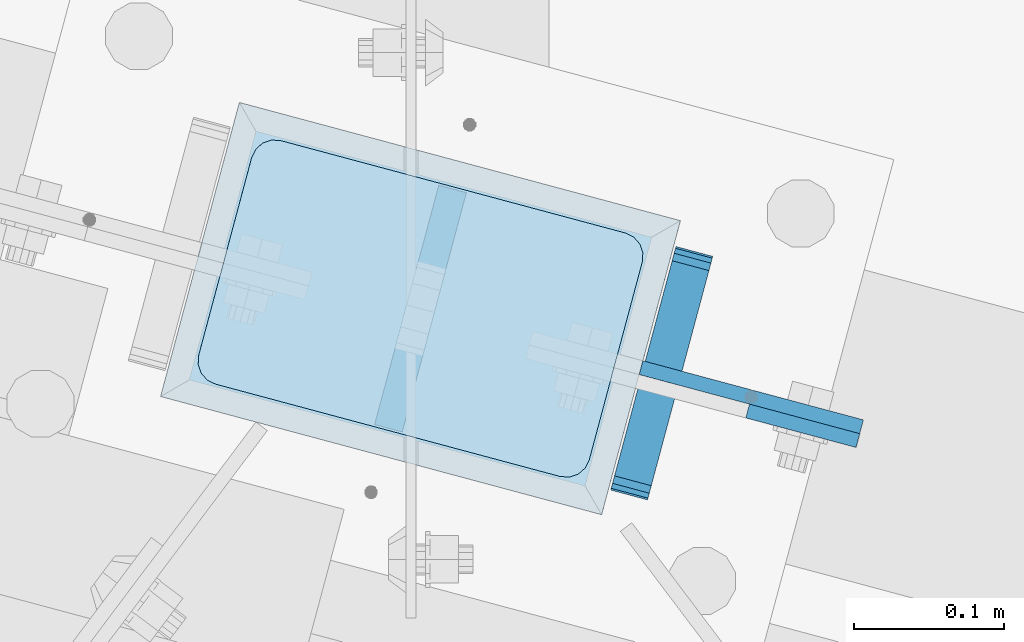
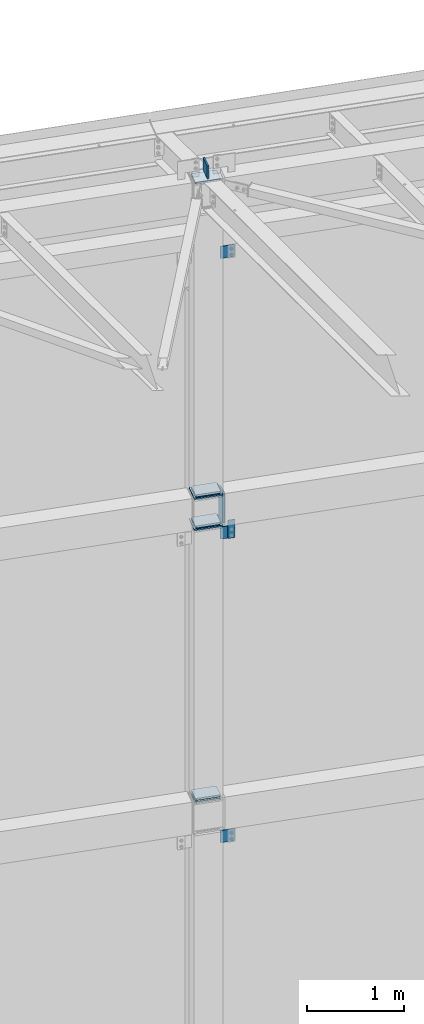
# One storey, part 1689 of 1763: 15 plates, 2 elements without a shape of their own.
"""IFC2X3 building model written with IfcOpenShell, lengths in millimetres."""

from ifc_helpers import new_model, si_unit, frame, origin_with_axes, place, context, subcontext, project, spatial, faceted_brep, material, type_object, element, aggregate, save


model = new_model("IFC2X3")

# Units and contexts
model_context = context("Model", 3, precision=1e-05, world=origin_with_axes())
body_context = subcontext(model_context, "Body", "Model", "MODEL_VIEW")
ifc_project = project(units=[si_unit("LENGTHUNIT", "METRE", prefix="MILLI"), si_unit("AREAUNIT", "SQUARE_METRE"), si_unit("VOLUMEUNIT", "CUBIC_METRE"), si_unit("MASSUNIT", "GRAM", prefix="KILO"), si_unit("TIMEUNIT", "SECOND"), si_unit("PLANEANGLEUNIT", "RADIAN"), si_unit("SOLIDANGLEUNIT", "STERADIAN"), si_unit("THERMODYNAMICTEMPERATUREUNIT", "DEGREE_CELSIUS"), si_unit("LUMINOUSINTENSITYUNIT", "LUMEN")], contexts=[model_context])

# Site, building, storey
site_placement = place(None, origin_with_axes())
site = spatial("IfcSite", under=ifc_project, at=site_placement, CompositionType="ELEMENT")
building_placement = place(site_placement, origin_with_axes())
building = spatial("IfcBuilding", under=site, at=building_placement, Name="Undefined", CompositionType="ELEMENT")
storey_placement = place(building_placement, origin_with_axes())
storey = spatial("IfcBuildingStorey", under=building, at=storey_placement, Name="Undefined", CompositionType="ELEMENT", Elevation=0.0)

# Assembly, plates
assembly_1_placement = place(storey_placement, origin_with_axes())
assembly_1 = element("IfcElementAssembly", 1, at=assembly_1_placement, inside=storey, Name="BEAM", AssemblyPlace="NOTDEFINED", PredefinedType="RIGID_FRAME")
ifc_material_1 = material(Name="STEEL/A36")
plate_type_1 = type_object("IfcPlateType", PredefinedType="NOTDEFINED")
plate_1_placement = place(assembly_1_placement, frame((-30890.9582946907, 64318.5909146449, 8077.19999084485), z_axis=(0.0, 0.0, -1.0), x_axis=(0.965925826295336, -0.25881904507913, 0.0)))
plate_1 = element("IfcPlate", 2, at=plate_1_placement, type_object=plate_type_1, material=ifc_material_1, Name="PLATE", context=body_context, shape_type="Brep", body=[
    faceted_brep([(0.0, -4.76249999999982, 0.0), (-2.83762346953154e-10, -4.7624999996915, 228.600006103516), (-2.83762346953154e-10, 4.76250000028813, 228.600006103517), (0.0, 4.76249999999982, 0.0), (76.1999969480166, -4.76249999961874, 228.600006103516), (76.1999969480166, 4.76250000036089, 228.600006103517), (76.1999969482931, -4.76249999991705, 0.0), (76.1999969482931, 4.76250000006257, 1.81898940354586e-12)], [[[0, 1, 2, 3]], [[1, 4, 5, 2]], [[4, 6, 7, 5]], [[6, 0, 3, 7]], [[5, 7, 3, 2]], [[6, 4, 1, 0]]]),
])
plate_type_2 = type_object("IfcPlateType", PredefinedType="NOTDEFINED")
plate_2_placement = place(assembly_1_placement, frame((-30926.5066305647, 64425.0894095407, 8094.69625868207), z_axis=(-1.25579324012506e-05, -4.68677477038e-05, 0.999999998822856), x_axis=(-0.258819045024454, -0.965925825091317, -4.85210000061005e-05)))
plate_2 = element("IfcPlate", 3, at=plate_2_placement, type_object=plate_type_2, material=ifc_material_1, Name="PLATE", context=body_context, shape_type="Brep", body=[
    faceted_brep([(-0.000210669619264081, -12.6999999999534, 15.8747893276304), (-0.0047190601399052, -12.6999999998734, 355.599795431186), (-0.00471906022721669, 12.7000000000335, 355.599795431181), (-0.000210669699299615, 12.6999999999462, 15.874789327625), (1.2036328949398, -12.6999999998734, 361.674959615151), (1.20363289484521, 12.7000000000189, 361.674959615146), (4.64488630341657, -12.6999999998734, 366.825251770753), (4.64488630330743, 12.7000000000189, 366.825251770748), (9.79513279069943, -12.6999999998807, 370.266573526937), (9.79513279059029, 12.7000000000116, 370.266573526933), (15.870280938434, -12.6999999998952, 371.47500610361), (15.8702809383467, 12.7000000000044, 371.475006103608), (152.395291187866, -12.7000000001281, 371.475006103574), (152.395291187757, 12.6999999997643, 371.475006103572), (158.470342028959, -12.7000000001353, 370.266613832635), (158.47034202885, 12.699999999757, 370.266613832629), (163.620536872309, -12.7000000001644, 366.825400721296), (163.620536872222, 12.6999999997352, 366.825400721291), (167.061818314192, -12.7000000001644, 361.675251535087), (167.06181831409, 12.6999999997279, 361.675251535082), (168.270291186484, -12.7000000001644, 355.600216727018), (168.270291186389, 12.6999999997279, 355.600216727014), (168.274798528968, -12.7000000002445, 15.8752106238717), (168.274798528873, 12.6999999996478, 15.8752106238662), (167.066446559853, -12.7000000002445, 9.80004645495683), (167.066446559766, 12.6999999996551, 9.80004645495319), (163.625193148131, -12.7000000002372, 4.64975431598214), (163.625193148022, 12.6999999996478, 4.64975431597668), (158.474946666858, -12.7000000002372, 1.2084325724245), (158.474946666771, 12.6999999996624, 1.20843257241904), (152.399798530452, -12.7000000002226, 4.20186552219093e-10), (152.399798530358, 12.6999999996697, 4.14729584008455e-10), (15.8747893290638, -12.6999999999898, 4.72937244921923e-11), (15.8747893289692, 12.6999999999098, 4.36557456851006e-11), (9.79973849928501, -12.699999999968, 1.20839226628777), (9.79973849918315, 12.6999999999243, 1.20839226628414), (4.64954366190068, -12.699999999968, 4.6496053649953), (4.64954366179882, 12.6999999999316, 4.64960536499166), (1.20826221675816, -12.6999999999607, 9.79975453459156), (1.20826221665629, 12.6999999999462, 9.79975453458792)], [[[0, 1, 2, 3]], [[1, 4, 5, 2]], [[4, 6, 7, 5]], [[6, 8, 9, 7]], [[8, 10, 11, 9]], [[10, 12, 13, 11]], [[12, 14, 15, 13]], [[14, 16, 17, 15]], [[16, 18, 19, 17]], [[18, 20, 21, 19]], [[20, 22, 23, 21]], [[22, 24, 25, 23]], [[24, 26, 27, 25]], [[26, 28, 29, 27]], [[28, 30, 31, 29]], [[30, 32, 33, 31]], [[32, 34, 35, 33]], [[34, 36, 37, 35]], [[36, 38, 39, 37]], [[38, 0, 3, 39]], [[5, 7, 9, 11, 13, 15, 17, 19, 21, 23, 25, 27, 29, 31, 33, 35, 37, 39, 3, 2]], [[38, 36, 34, 32, 30, 28, 26, 24, 22, 20, 18, 16, 14, 12, 10, 8, 6, 4, 1, 0]]]),
])
aggregate(assembly_1, [plate_2, plate_1])

assembly_2_placement = place(storey_placement, origin_with_axes())
assembly_2 = element("IfcElementAssembly", 4, at=assembly_2_placement, inside=storey, Name="COLUMN", AssemblyPlace="NOTDEFINED", PredefinedType="RIGID_FRAME")
plate_3_placement = place(assembly_2_placement, frame((-31217.8672023227, 64503.1592394629, 12417.425), z_axis=(0.965913267114843, -0.258865912030785, 0.0), x_axis=(-0.258865912030778, -0.965913267114844, 3.00823476209188e-08)))
plate_3 = element("IfcPlate", 5, at=plate_3_placement, type_object=plate_type_2, material=ifc_material_1, Name="PLATE", context=body_context, shape_type="Brep", body=[
    faceted_brep([(-2.18278728425503e-11, -12.7000000000007, 15.875), (-1.67347025126219e-10, -12.7000000000007, 253.999999999985), (-1.67347025126219e-10, 12.7000000000007, 253.999999999985), (-2.18278728425503e-11, 12.7000000000007, 15.875), (1.20841242121242, -12.7000000000007, 260.075099488779), (1.20841242121242, 12.7000000000007, 260.075099488779), (4.649679848495, -12.7000000000007, 265.225320151323), (4.649679848495, 12.7000000000007, 265.225320151323), (9.79990051103232, -12.7000000000007, 268.666587578606), (9.79990051103232, 12.7000000000007, 268.666587578606), (15.8749999998181, -12.7000000000007, 269.874999999993), (15.8749999998181, 12.7000000000007, 269.874999999993), (152.400009155084, -12.7000000000007, 269.875000000073), (152.400009155084, 12.7000000000007, 269.875000000073), (158.475108643877, -12.7000000000007, 268.6665875787), (158.475108643877, 12.7000000000007, 268.6665875787), (163.625329306422, -12.7000000000007, 265.225320151425), (163.625329306422, 12.7000000000007, 265.225320151425), (167.066596733705, -12.7000000000007, 260.07509948888), (167.066596733705, 12.7000000000007, 260.07509948888), (168.275009155092, -12.7000000000007, 254.000000000087), (168.275009155092, 12.7000000000007, 254.000000000087), (168.275009155237, -12.7000000000007, 15.8750000001019), (168.275009155237, 12.7000000000007, 15.8750000001019), (167.066596733865, -12.7000000000007, 9.79990051130881), (167.066596733865, 12.7000000000007, 9.79990051130881), (163.625329306582, -12.7000000000007, 4.64967984876421), (163.625329306582, 12.7000000000007, 4.64967984876421), (158.475108644045, -12.7000000000007, 1.20841242148163), (158.475108644045, 12.7000000000007, 1.20841242148163), (152.400000000001, -12.6999998092651, 0.0), (152.400000000001, 12.6999998092651, 0.0), (15.8749999999854, -12.7000000000007, 0.0), (15.8749999999854, 12.7000000000007, 0.0), (9.79990051119239, -12.7000000000007, 1.20841242137976), (9.79990051119239, 12.7000000000007, 1.20841242137976), (4.64967984864779, -12.7000000000007, 4.64967984866234), (4.64967984864779, 12.7000000000007, 4.64967984866234), (1.20841242136521, -12.7000000000007, 9.79990051119967), (1.20841242136521, 12.7000000000007, 9.79990051119967)], [[[0, 1, 2, 3]], [[1, 4, 5, 2]], [[4, 6, 7, 5]], [[6, 8, 9, 7]], [[8, 10, 11, 9]], [[10, 12, 13, 11]], [[12, 14, 15, 13]], [[14, 16, 17, 15]], [[16, 18, 19, 17]], [[18, 20, 21, 19]], [[20, 22, 23, 21]], [[22, 24, 25, 23]], [[24, 26, 27, 25]], [[26, 28, 29, 27]], [[28, 30, 31, 29]], [[30, 32, 33, 31]], [[32, 34, 35, 33]], [[34, 36, 37, 35]], [[36, 38, 39, 37]], [[38, 0, 3, 39]], [[5, 7, 9, 11, 13, 15, 17, 19, 21, 23, 25, 27, 29, 31, 33, 35, 37, 39, 3, 2]], [[38, 36, 34, 32, 30, 28, 26, 24, 22, 20, 18, 16, 14, 12, 10, 8, 6, 4, 1, 0]]]),
])
plate_4_placement = place(assembly_2_placement, frame((-31217.8672020656, 64503.159239394, 8496.3), z_axis=(0.965913267114843, -0.258865912030785, 0.0), x_axis=(-0.258865912030778, -0.965913267114844, 3.00823476209188e-08)))
plate_4 = element("IfcPlate", 6, at=plate_4_placement, type_object=plate_type_2, material=ifc_material_1, Name="PLATE", context=body_context, shape_type="Brep", body=[
    faceted_brep([(-2.18278728425503e-11, -12.7000000000007, 15.875), (-1.67347025126219e-10, -12.7000000000007, 253.999999999985), (-1.67347025126219e-10, 12.7000000000007, 253.999999999985), (-2.18278728425503e-11, 12.7000000000007, 15.875), (1.20841242121242, -12.7000000000007, 260.075099488779), (1.20841242121242, 12.7000000000007, 260.075099488779), (4.649679848495, -12.7000000000007, 265.225320151323), (4.649679848495, 12.7000000000007, 265.225320151323), (9.79990051103232, -12.7000000000007, 268.666587578606), (9.79990051103232, 12.7000000000007, 268.666587578606), (15.8749999998181, -12.7000000000007, 269.874999999993), (15.8749999998181, 12.7000000000007, 269.874999999993), (152.400009155084, -12.7000000000007, 269.875000000073), (152.400009155084, 12.7000000000007, 269.875000000073), (158.475108643877, -12.7000000000007, 268.6665875787), (158.475108643877, 12.7000000000007, 268.6665875787), (163.625329306422, -12.7000000000007, 265.225320151425), (163.625329306422, 12.7000000000007, 265.225320151425), (167.066596733705, -12.7000000000007, 260.07509948888), (167.066596733705, 12.7000000000007, 260.07509948888), (168.275009155092, -12.7000000000007, 254.000000000087), (168.275009155092, 12.7000000000007, 254.000000000087), (168.275009155237, -12.7000000000007, 15.8750000001019), (168.275009155237, 12.7000000000007, 15.8750000001019), (167.066596733865, -12.7000000000007, 9.79990051130881), (167.066596733865, 12.7000000000007, 9.79990051130881), (163.625329306582, -12.7000000000007, 4.64967984876421), (163.625329306582, 12.7000000000007, 4.64967984876421), (158.475108644045, -12.7000000000007, 1.20841242148163), (158.475108644045, 12.7000000000007, 1.20841242148163), (152.400000000001, -12.6999998092651, 0.0), (152.400000000001, 12.6999998092651, 0.0), (15.8749999999854, -12.7000000000007, 0.0), (15.8749999999854, 12.7000000000007, 0.0), (9.79990051119239, -12.7000000000007, 1.20841242137976), (9.79990051119239, 12.7000000000007, 1.20841242137976), (4.64967984864779, -12.7000000000007, 4.64967984866234), (4.64967984864779, 12.7000000000007, 4.64967984866234), (1.20841242136521, -12.7000000000007, 9.79990051119967), (1.20841242136521, 12.7000000000007, 9.79990051119967)], [[[0, 1, 2, 3]], [[1, 4, 5, 2]], [[4, 6, 7, 5]], [[6, 8, 9, 7]], [[8, 10, 11, 9]], [[10, 12, 13, 11]], [[12, 14, 15, 13]], [[14, 16, 17, 15]], [[16, 18, 19, 17]], [[18, 20, 21, 19]], [[20, 22, 23, 21]], [[22, 24, 25, 23]], [[24, 26, 27, 25]], [[26, 28, 29, 27]], [[28, 30, 31, 29]], [[30, 32, 33, 31]], [[32, 34, 35, 33]], [[34, 36, 37, 35]], [[36, 38, 39, 37]], [[38, 0, 3, 39]], [[5, 7, 9, 11, 13, 15, 17, 19, 21, 23, 25, 27, 29, 31, 33, 35, 37, 39, 3, 2]], [[38, 36, 34, 32, 30, 28, 26, 24, 22, 20, 18, 16, 14, 12, 10, 8, 6, 4, 1, 0]]]),
])
plate_5_placement = place(assembly_2_placement, frame((-31217.8672021029, 64503.159239404, 8455.025), z_axis=(0.965913267114843, -0.258865912030785, 0.0), x_axis=(-0.258865912030778, -0.965913267114844, 3.00823476209188e-08)))
plate_5 = element("IfcPlate", 7, at=plate_5_placement, type_object=plate_type_2, material=ifc_material_1, Name="PLATE", context=body_context, shape_type="Brep", body=[
    faceted_brep([(-2.18278728425503e-11, -12.7000000000007, 15.875), (-1.67347025126219e-10, -12.7000000000007, 253.999999999985), (-1.67347025126219e-10, 12.7000000000007, 253.999999999985), (-2.18278728425503e-11, 12.7000000000007, 15.875), (1.20841242121242, -12.7000000000007, 260.075099488779), (1.20841242121242, 12.7000000000007, 260.075099488779), (4.649679848495, -12.7000000000007, 265.225320151323), (4.649679848495, 12.7000000000007, 265.225320151323), (9.79990051103232, -12.7000000000007, 268.666587578606), (9.79990051103232, 12.7000000000007, 268.666587578606), (15.8749999998181, -12.7000000000007, 269.874999999993), (15.8749999998181, 12.7000000000007, 269.874999999993), (152.400009155084, -12.7000000000007, 269.875000000073), (152.400009155084, 12.7000000000007, 269.875000000073), (158.475108643877, -12.7000000000007, 268.6665875787), (158.475108643877, 12.7000000000007, 268.6665875787), (163.625329306422, -12.7000000000007, 265.225320151425), (163.625329306422, 12.7000000000007, 265.225320151425), (167.066596733705, -12.7000000000007, 260.07509948888), (167.066596733705, 12.7000000000007, 260.07509948888), (168.275009155092, -12.7000000000007, 254.000000000087), (168.275009155092, 12.7000000000007, 254.000000000087), (168.275009155237, -12.7000000000007, 15.8750000001019), (168.275009155237, 12.7000000000007, 15.8750000001019), (167.066596733865, -12.7000000000007, 9.79990051130881), (167.066596733865, 12.7000000000007, 9.79990051130881), (163.625329306582, -12.7000000000007, 4.64967984876421), (163.625329306582, 12.7000000000007, 4.64967984876421), (158.475108644045, -12.7000000000007, 1.20841242148163), (158.475108644045, 12.7000000000007, 1.20841242148163), (152.400000000001, -12.6999998092651, 0.0), (152.400000000001, 12.6999998092651, 0.0), (15.8749999999854, -12.7000000000007, 0.0), (15.8749999999854, 12.7000000000007, 0.0), (9.79990051119239, -12.7000000000007, 1.20841242137976), (9.79990051119239, 12.7000000000007, 1.20841242137976), (4.64967984864779, -12.7000000000007, 4.64967984866234), (4.64967984864779, 12.7000000000007, 4.64967984866234), (1.20841242136521, -12.7000000000007, 9.79990051119967), (1.20841242136521, 12.7000000000007, 9.79990051119967)], [[[0, 1, 2, 3]], [[1, 4, 5, 2]], [[4, 6, 7, 5]], [[6, 8, 9, 7]], [[8, 10, 11, 9]], [[10, 12, 13, 11]], [[12, 14, 15, 13]], [[14, 16, 17, 15]], [[16, 18, 19, 17]], [[18, 20, 21, 19]], [[20, 22, 23, 21]], [[22, 24, 25, 23]], [[24, 26, 27, 25]], [[26, 28, 29, 27]], [[28, 30, 31, 29]], [[30, 32, 33, 31]], [[32, 34, 35, 33]], [[34, 36, 37, 35]], [[36, 38, 39, 37]], [[38, 0, 3, 39]], [[5, 7, 9, 11, 13, 15, 17, 19, 21, 23, 25, 27, 29, 31, 33, 35, 37, 39, 3, 2]], [[38, 36, 34, 32, 30, 28, 26, 24, 22, 20, 18, 16, 14, 12, 10, 8, 6, 4, 1, 0]]]),
])
plate_6_placement = place(assembly_2_placement, frame((-31217.8767256758, 64503.1617912377, 8105.775), z_axis=(0.965913267114843, -0.258865912030785, 0.0), x_axis=(-0.258865912030778, -0.965913267114844, 3.00823476209188e-08)))
plate_6 = element("IfcPlate", 8, at=plate_6_placement, type_object=plate_type_2, material=ifc_material_1, Name="PLATE", context=body_context, shape_type="Brep", body=[
    faceted_brep([(-2.18278728425503e-11, -12.7000000000007, 15.875), (-1.67347025126219e-10, -12.7000000000007, 253.999999999985), (-1.67347025126219e-10, 12.7000000000007, 253.999999999985), (-2.18278728425503e-11, 12.7000000000007, 15.875), (1.20841242121242, -12.7000000000007, 260.075099488779), (1.20841242121242, 12.7000000000007, 260.075099488779), (4.649679848495, -12.7000000000007, 265.225320151323), (4.649679848495, 12.7000000000007, 265.225320151323), (9.79990051103232, -12.7000000000007, 268.666587578606), (9.79990051103232, 12.7000000000007, 268.666587578606), (15.8749999998181, -12.7000000000007, 269.874999999993), (15.8749999998181, 12.7000000000007, 269.874999999993), (152.400009155084, -12.7000000000007, 269.875000000073), (152.400009155084, 12.7000000000007, 269.875000000073), (158.475108643877, -12.7000000000007, 268.6665875787), (158.475108643877, 12.7000000000007, 268.6665875787), (163.625329306422, -12.7000000000007, 265.225320151425), (163.625329306422, 12.7000000000007, 265.225320151425), (167.066596733705, -12.7000000000007, 260.07509948888), (167.066596733705, 12.7000000000007, 260.07509948888), (168.275009155092, -12.7000000000007, 254.000000000087), (168.275009155092, 12.7000000000007, 254.000000000087), (168.275009155237, -12.7000000000007, 15.8750000001019), (168.275009155237, 12.7000000000007, 15.8750000001019), (167.066596733865, -12.7000000000007, 9.79990051130881), (167.066596733865, 12.7000000000007, 9.79990051130881), (163.625329306582, -12.7000000000007, 4.64967984876421), (163.625329306582, 12.7000000000007, 4.64967984876421), (158.475108644045, -12.7000000000007, 1.20841242148163), (158.475108644045, 12.7000000000007, 1.20841242148163), (152.400000000001, -12.6999998092651, 0.0), (152.400000000001, 12.6999998092651, 0.0), (15.8749999999854, -12.7000000000007, 0.0), (15.8749999999854, 12.7000000000007, 0.0), (9.79990051119239, -12.7000000000007, 1.20841242137976), (9.79990051119239, 12.7000000000007, 1.20841242137976), (4.64967984864779, -12.7000000000007, 4.64967984866234), (4.64967984864779, 12.7000000000007, 4.64967984866234), (1.20841242136521, -12.7000000000007, 9.79990051119967), (1.20841242136521, 12.7000000000007, 9.79990051119967)], [[[0, 1, 2, 3]], [[1, 4, 5, 2]], [[4, 6, 7, 5]], [[6, 8, 9, 7]], [[8, 10, 11, 9]], [[10, 12, 13, 11]], [[12, 14, 15, 13]], [[14, 16, 17, 15]], [[16, 18, 19, 17]], [[18, 20, 21, 19]], [[20, 22, 23, 21]], [[22, 24, 25, 23]], [[24, 26, 27, 25]], [[26, 28, 29, 27]], [[28, 30, 31, 29]], [[30, 32, 33, 31]], [[32, 34, 35, 33]], [[34, 36, 37, 35]], [[36, 38, 39, 37]], [[38, 0, 3, 39]], [[5, 7, 9, 11, 13, 15, 17, 19, 21, 23, 25, 27, 29, 31, 33, 35, 37, 39, 3, 2]], [[38, 36, 34, 32, 30, 28, 26, 24, 22, 20, 18, 16, 14, 12, 10, 8, 6, 4, 1, 0]]]),
])
plate_7_placement = place(assembly_2_placement, frame((-31217.8767257132, 64503.1617912477, 8064.5), z_axis=(0.965913267114843, -0.258865912030785, 0.0), x_axis=(-0.258865912030778, -0.965913267114844, 3.00823476209188e-08)))
plate_7 = element("IfcPlate", 9, at=plate_7_placement, type_object=plate_type_2, material=ifc_material_1, Name="PLATE", context=body_context, shape_type="Brep", body=[
    faceted_brep([(-2.18278728425503e-11, -12.7000000000007, 15.875), (-1.67347025126219e-10, -12.7000000000007, 253.999999999985), (-1.67347025126219e-10, 12.7000000000007, 253.999999999985), (-2.18278728425503e-11, 12.7000000000007, 15.875), (1.20841242121242, -12.7000000000007, 260.075099488779), (1.20841242121242, 12.7000000000007, 260.075099488779), (4.649679848495, -12.7000000000007, 265.225320151323), (4.649679848495, 12.7000000000007, 265.225320151323), (9.79990051103232, -12.7000000000007, 268.666587578606), (9.79990051103232, 12.7000000000007, 268.666587578606), (15.8749999998181, -12.7000000000007, 269.874999999993), (15.8749999998181, 12.7000000000007, 269.874999999993), (152.400009155084, -12.7000000000007, 269.875000000073), (152.400009155084, 12.7000000000007, 269.875000000073), (158.475108643877, -12.7000000000007, 268.6665875787), (158.475108643877, 12.7000000000007, 268.6665875787), (163.625329306422, -12.7000000000007, 265.225320151425), (163.625329306422, 12.7000000000007, 265.225320151425), (167.066596733705, -12.7000000000007, 260.07509948888), (167.066596733705, 12.7000000000007, 260.07509948888), (168.275009155092, -12.7000000000007, 254.000000000087), (168.275009155092, 12.7000000000007, 254.000000000087), (168.275009155237, -12.7000000000007, 15.8750000001019), (168.275009155237, 12.7000000000007, 15.8750000001019), (167.066596733865, -12.7000000000007, 9.79990051130881), (167.066596733865, 12.7000000000007, 9.79990051130881), (163.625329306582, -12.7000000000007, 4.64967984876421), (163.625329306582, 12.7000000000007, 4.64967984876421), (158.475108644045, -12.7000000000007, 1.20841242148163), (158.475108644045, 12.7000000000007, 1.20841242148163), (152.400000000001, -12.6999998092651, 0.0), (152.400000000001, 12.6999998092651, 0.0), (15.8749999999854, -12.7000000000007, 0.0), (15.8749999999854, 12.7000000000007, 0.0), (9.79990051119239, -12.7000000000007, 1.20841242137976), (9.79990051119239, 12.7000000000007, 1.20841242137976), (4.64967984864779, -12.7000000000007, 4.64967984866234), (4.64967984864779, 12.7000000000007, 4.64967984866234), (1.20841242136521, -12.7000000000007, 9.79990051119967), (1.20841242136521, 12.7000000000007, 9.79990051119967)], [[[0, 1, 2, 3]], [[1, 4, 5, 2]], [[4, 6, 7, 5]], [[6, 8, 9, 7]], [[8, 10, 11, 9]], [[10, 12, 13, 11]], [[12, 14, 15, 13]], [[14, 16, 17, 15]], [[16, 18, 19, 17]], [[18, 20, 21, 19]], [[20, 22, 23, 21]], [[22, 24, 25, 23]], [[24, 26, 27, 25]], [[26, 28, 29, 27]], [[28, 30, 31, 29]], [[30, 32, 33, 31]], [[32, 34, 35, 33]], [[34, 36, 37, 35]], [[36, 38, 39, 37]], [[38, 0, 3, 39]], [[5, 7, 9, 11, 13, 15, 17, 19, 21, 23, 25, 27, 29, 31, 33, 35, 37, 39, 3, 2]], [[38, 36, 34, 32, 30, 28, 26, 24, 22, 20, 18, 16, 14, 12, 10, 8, 6, 4, 1, 0]]]),
])
plate_8_placement = place(assembly_2_placement, frame((-31217.867202211, 64503.159239433, 4686.3), z_axis=(0.965913267114843, -0.258865912030785, 0.0), x_axis=(-0.258865912030778, -0.965913267114844, 3.00823476209188e-08)))
plate_8 = element("IfcPlate", 10, at=plate_8_placement, type_object=plate_type_2, material=ifc_material_1, Name="PLATE", context=body_context, shape_type="Brep", body=[
    faceted_brep([(-2.18278728425503e-11, -12.7000000000007, 15.875), (-1.67347025126219e-10, -12.7000000000007, 253.999999999985), (-1.67347025126219e-10, 12.7000000000007, 253.999999999985), (-2.18278728425503e-11, 12.7000000000007, 15.875), (1.20841242121242, -12.7000000000007, 260.075099488779), (1.20841242121242, 12.7000000000007, 260.075099488779), (4.649679848495, -12.7000000000007, 265.225320151323), (4.649679848495, 12.7000000000007, 265.225320151323), (9.79990051103232, -12.7000000000007, 268.666587578606), (9.79990051103232, 12.7000000000007, 268.666587578606), (15.8749999998181, -12.7000000000007, 269.874999999993), (15.8749999998181, 12.7000000000007, 269.874999999993), (152.400009155084, -12.7000000000007, 269.875000000073), (152.400009155084, 12.7000000000007, 269.875000000073), (158.475108643877, -12.7000000000007, 268.6665875787), (158.475108643877, 12.7000000000007, 268.6665875787), (163.625329306422, -12.7000000000007, 265.225320151425), (163.625329306422, 12.7000000000007, 265.225320151425), (167.066596733705, -12.7000000000007, 260.07509948888), (167.066596733705, 12.7000000000007, 260.07509948888), (168.275009155092, -12.7000000000007, 254.000000000087), (168.275009155092, 12.7000000000007, 254.000000000087), (168.275009155237, -12.7000000000007, 15.8750000001019), (168.275009155237, 12.7000000000007, 15.8750000001019), (167.066596733865, -12.7000000000007, 9.79990051130881), (167.066596733865, 12.7000000000007, 9.79990051130881), (163.625329306582, -12.7000000000007, 4.64967984876421), (163.625329306582, 12.7000000000007, 4.64967984876421), (158.475108644045, -12.7000000000007, 1.20841242148163), (158.475108644045, 12.7000000000007, 1.20841242148163), (152.400000000001, -12.6999998092651, 0.0), (152.400000000001, 12.6999998092651, 0.0), (15.8749999999854, -12.7000000000007, 0.0), (15.8749999999854, 12.7000000000007, 0.0), (9.79990051119239, -12.7000000000007, 1.20841242137976), (9.79990051119239, 12.7000000000007, 1.20841242137976), (4.64967984864779, -12.7000000000007, 4.64967984866234), (4.64967984864779, 12.7000000000007, 4.64967984866234), (1.20841242136521, -12.7000000000007, 9.79990051119967), (1.20841242136521, 12.7000000000007, 9.79990051119967)], [[[0, 1, 2, 3]], [[1, 4, 5, 2]], [[4, 6, 7, 5]], [[6, 8, 9, 7]], [[8, 10, 11, 9]], [[10, 12, 13, 11]], [[12, 14, 15, 13]], [[14, 16, 17, 15]], [[16, 18, 19, 17]], [[18, 20, 21, 19]], [[20, 22, 23, 21]], [[22, 24, 25, 23]], [[24, 26, 27, 25]], [[26, 28, 29, 27]], [[28, 30, 31, 29]], [[30, 32, 33, 31]], [[32, 34, 35, 33]], [[34, 36, 37, 35]], [[36, 38, 39, 37]], [[38, 0, 3, 39]], [[5, 7, 9, 11, 13, 15, 17, 19, 21, 23, 25, 27, 29, 31, 33, 35, 37, 39, 3, 2]], [[38, 36, 34, 32, 30, 28, 26, 24, 22, 20, 18, 16, 14, 12, 10, 8, 6, 4, 1, 0]]]),
])
plate_9_placement = place(assembly_2_placement, frame((-31217.8672022483, 64503.159239443, 4645.025), z_axis=(0.965913267114843, -0.258865912030785, 0.0), x_axis=(-0.258865912030778, -0.965913267114844, 3.00823476209188e-08)))
plate_9 = element("IfcPlate", 11, at=plate_9_placement, type_object=plate_type_2, material=ifc_material_1, Name="PLATE", context=body_context, shape_type="Brep", body=[
    faceted_brep([(-2.18278728425503e-11, -12.7000000000007, 15.875), (-1.67347025126219e-10, -12.7000000000007, 253.999999999985), (-1.67347025126219e-10, 12.7000000000007, 253.999999999985), (-2.18278728425503e-11, 12.7000000000007, 15.875), (1.20841242121242, -12.7000000000007, 260.075099488779), (1.20841242121242, 12.7000000000007, 260.075099488779), (4.649679848495, -12.7000000000007, 265.225320151323), (4.649679848495, 12.7000000000007, 265.225320151323), (9.79990051103232, -12.7000000000007, 268.666587578606), (9.79990051103232, 12.7000000000007, 268.666587578606), (15.8749999998181, -12.7000000000007, 269.874999999993), (15.8749999998181, 12.7000000000007, 269.874999999993), (152.400009155084, -12.7000000000007, 269.875000000073), (152.400009155084, 12.7000000000007, 269.875000000073), (158.475108643877, -12.7000000000007, 268.6665875787), (158.475108643877, 12.7000000000007, 268.6665875787), (163.625329306422, -12.7000000000007, 265.225320151425), (163.625329306422, 12.7000000000007, 265.225320151425), (167.066596733705, -12.7000000000007, 260.07509948888), (167.066596733705, 12.7000000000007, 260.07509948888), (168.275009155092, -12.7000000000007, 254.000000000087), (168.275009155092, 12.7000000000007, 254.000000000087), (168.275009155237, -12.7000000000007, 15.8750000001019), (168.275009155237, 12.7000000000007, 15.8750000001019), (167.066596733865, -12.7000000000007, 9.79990051130881), (167.066596733865, 12.7000000000007, 9.79990051130881), (163.625329306582, -12.7000000000007, 4.64967984876421), (163.625329306582, 12.7000000000007, 4.64967984876421), (158.475108644045, -12.7000000000007, 1.20841242148163), (158.475108644045, 12.7000000000007, 1.20841242148163), (152.400000000001, -12.6999998092651, 0.0), (152.400000000001, 12.6999998092651, 0.0), (15.8749999999854, -12.7000000000007, 0.0), (15.8749999999854, 12.7000000000007, 0.0), (9.79990051119239, -12.7000000000007, 1.20841242137976), (9.79990051119239, 12.7000000000007, 1.20841242137976), (4.64967984864779, -12.7000000000007, 4.64967984866234), (4.64967984864779, 12.7000000000007, 4.64967984866234), (1.20841242136521, -12.7000000000007, 9.79990051119967), (1.20841242136521, 12.7000000000007, 9.79990051119967)], [[[0, 1, 2, 3]], [[1, 4, 5, 2]], [[4, 6, 7, 5]], [[6, 8, 9, 7]], [[8, 10, 11, 9]], [[10, 12, 13, 11]], [[12, 14, 15, 13]], [[14, 16, 17, 15]], [[16, 18, 19, 17]], [[18, 20, 21, 19]], [[20, 22, 23, 21]], [[22, 24, 25, 23]], [[24, 26, 27, 25]], [[26, 28, 29, 27]], [[28, 30, 31, 29]], [[30, 32, 33, 31]], [[32, 34, 35, 33]], [[34, 36, 37, 35]], [[36, 38, 39, 37]], [[38, 0, 3, 39]], [[5, 7, 9, 11, 13, 15, 17, 19, 21, 23, 25, 27, 29, 31, 33, 35, 37, 39, 3, 2]], [[38, 36, 34, 32, 30, 28, 26, 24, 22, 20, 18, 16, 14, 12, 10, 8, 6, 4, 1, 0]]]),
])
ifc_material_2 = material(Name="STEEL/A572-50")
plate_type_3 = type_object("IfcPlateType", PredefinedType="NOTDEFINED")
plate_10_placement = place(assembly_2_placement, frame((-31230.2044872932, 64524.5443924659, 8475.6625), z_axis=(0.965913267114843, -0.258865912030785, 0.0), x_axis=(-0.258865912030778, -0.965913267114844, 3.00823476209188e-08)))
plate_10 = element("IfcPlate", 12, at=plate_10_placement, type_object=plate_type_3, material=ifc_material_2, Name="PLATE", context=body_context, shape_type="Brep", body=[
    faceted_brep([(-7.27595761418343e-12, -7.9375, 0.0), (-1.96450855582952e-10, -7.9375, 304.799987792954), (-1.96450855582952e-10, 7.9375, 304.799987792954), (-7.27595761418343e-12, 7.9375, 0.0), (203.199996948031, -7.9375, 304.799987793078), (203.199996948031, 7.9375, 304.799987793078), (203.199996948228, -7.9375, 1.30967237055302e-10), (203.199996948228, 7.9375, 1.30967237055302e-10)], [[[0, 1, 2, 3]], [[1, 4, 5, 2]], [[4, 6, 7, 5]], [[6, 0, 3, 7]], [[5, 7, 3, 2]], [[6, 4, 1, 0]]]),
])
plate_11_placement = place(assembly_2_placement, frame((-31230.2140109035, 64524.5469443095, 8085.1375), z_axis=(0.965913267114843, -0.258865912030785, 0.0), x_axis=(-0.258865912030778, -0.965913267114844, 3.00823476209188e-08)))
plate_11 = element("IfcPlate", 13, at=plate_11_placement, type_object=plate_type_3, material=ifc_material_2, Name="PLATE", context=body_context, shape_type="Brep", body=[
    faceted_brep([(-7.27595761418343e-12, -7.9375, 0.0), (-1.96450855582952e-10, -7.9375, 304.799987792954), (-1.96450855582952e-10, 7.9375, 304.799987792954), (-7.27595761418343e-12, 7.9375, 0.0), (203.199996948031, -7.9375, 304.799987793078), (203.199996948031, 7.9375, 304.799987793078), (203.199996948228, -7.9375, 1.30967237055302e-10), (203.199996948228, 7.9375, 1.30967237055302e-10)], [[[0, 1, 2, 3]], [[1, 4, 5, 2]], [[4, 6, 7, 5]], [[6, 0, 3, 7]], [[5, 7, 3, 2]], [[6, 4, 1, 0]]]),
])
plate_type_4 = type_object("IfcPlateType", PredefinedType="NOTDEFINED")
plate_12_placement = place(assembly_2_placement, frame((-30814.895429165, 64308.0709473627, 4038.59998474133), z_axis=(0.0, 0.0, 1.0), x_axis=(-0.965925827679309, 0.258819039914073, 0.0)))
plate_12 = element("IfcPlate", 14, at=plate_12_placement, type_object=plate_type_4, material=ifc_material_1, Name="PLATE", context=body_context, shape_type="Brep", body=[
    faceted_brep([(0.0, -4.76249999999982, 0.0), (-3.05175672110636e-06, -4.7625000002663, 152.399993896484), (-3.05175490211695e-06, 4.76249999972788, 152.399993896484), (0.0, 4.76249999999982, 0.0), (152.400009155272, -4.76249999975698, 152.399993896484), (152.400009155273, 4.76250000024447, 152.399993896484), (152.400009155272, -4.76249999948777, 5.45696821063757e-12), (152.400009155273, 4.76250000051368, 3.63797880709171e-12)], [[[0, 1, 2, 3]], [[1, 4, 5, 2]], [[4, 6, 7, 5]], [[6, 0, 3, 7]], [[5, 7, 3, 2]], [[6, 4, 1, 0]]]),
])
plate_13_placement = place(assembly_2_placement, frame((-30814.895429165, 64308.0709473627, 7848.59998474133), z_axis=(0.0, 0.0, 1.0), x_axis=(-0.965925827679309, 0.258819039914073, 0.0)))
plate_13 = element("IfcPlate", 15, at=plate_13_placement, type_object=plate_type_4, material=ifc_material_1, Name="PLATE", context=body_context, shape_type="Brep", body=[
    faceted_brep([(0.0, -4.76249999999982, 0.0), (-3.05175672110636e-06, -4.7625000002663, 152.399993896484), (-3.05175490211695e-06, 4.76249999972788, 152.399993896484), (0.0, 4.76249999999982, 0.0), (152.400009155272, -4.76249999975698, 152.399993896484), (152.400009155273, 4.76250000024447, 152.399993896484), (152.400009155272, -4.76249999948777, 5.45696821063757e-12), (152.400009155273, 4.76250000051368, 3.63797880709171e-12)], [[[0, 1, 2, 3]], [[1, 4, 5, 2]], [[4, 6, 7, 5]], [[6, 0, 3, 7]], [[5, 7, 3, 2]], [[6, 4, 1, 0]]]),
])
plate_14_placement = place(assembly_2_placement, frame((-30814.8954058056, 64308.0709411022, 11369.6749847413), z_axis=(0.0, 0.0, 1.0), x_axis=(-0.965925827679309, 0.258819039914073, 0.0)))
plate_14 = element("IfcPlate", 16, at=plate_14_placement, type_object=plate_type_4, material=ifc_material_1, Name="PLATE", context=body_context, shape_type="Brep", body=[
    faceted_brep([(0.0, -4.76249999999982, 0.0), (-3.05175672110636e-06, -4.7625000002663, 152.399993896484), (-3.05175490211695e-06, 4.76249999972788, 152.399993896484), (0.0, 4.76249999999982, 0.0), (152.400009155272, -4.76249999975698, 152.399993896484), (152.400009155273, 4.76250000024447, 152.399993896484), (152.400009155272, -4.76249999948777, 5.45696821063757e-12), (152.400009155273, 4.76250000051368, 3.63797880709171e-12)], [[[0, 1, 2, 3]], [[1, 4, 5, 2]], [[4, 6, 7, 5]], [[6, 0, 3, 7]], [[5, 7, 3, 2]], [[6, 4, 1, 0]]]),
])
plate_type_5 = type_object("IfcPlateType", PredefinedType="NOTDEFINED")
plate_15_placement = place(assembly_2_placement, frame((-31087.9121778552, 64466.7853706736, 12611.0999938965), z_axis=(0.0, 0.0, -1.0), x_axis=(-0.258911937048181, -0.965900931179776, 0.0)))
plate_15 = element("IfcPlate", 17, at=plate_15_placement, type_object=plate_type_5, material=ifc_material_2, Name="PLATE", context=body_context, shape_type="Brep", body=[
    faceted_brep([(7.27595761418343e-12, 9.52500000000146, 155.574990844727), (-1.45519152283669e-11, 7.27595761418343e-12, 165.099990844727), (165.288833618244, 2.18278728425503e-10, 165.099990844727), (165.288833618273, 9.52500000021973, 155.574990844727), (-3.63797880709171e-11, -9.5249999999869, 155.574990844727), (165.288833618222, -9.5249999997759, 155.574990844727), (0.0, 9.52500000000146, 0.0), (0.0, -9.52500000000146, 0.0), (165.288833618222, -9.5249999997759, 0.0), (165.288833618273, 9.52500000021973, 0.0)], [[[0, 1, 2, 3]], [[1, 4, 5, 2]], [[6, 7, 4, 1, 0]], [[5, 8, 9, 3, 2]], [[8, 7, 6, 9]], [[9, 6, 0, 3]], [[7, 8, 5, 4]]]),
])
aggregate(assembly_2, [plate_15, plate_12, plate_13, plate_14, plate_3, plate_4, plate_5, plate_10, plate_6, plate_7, plate_11, plate_8, plate_9])

save(model, "model.ifc")
